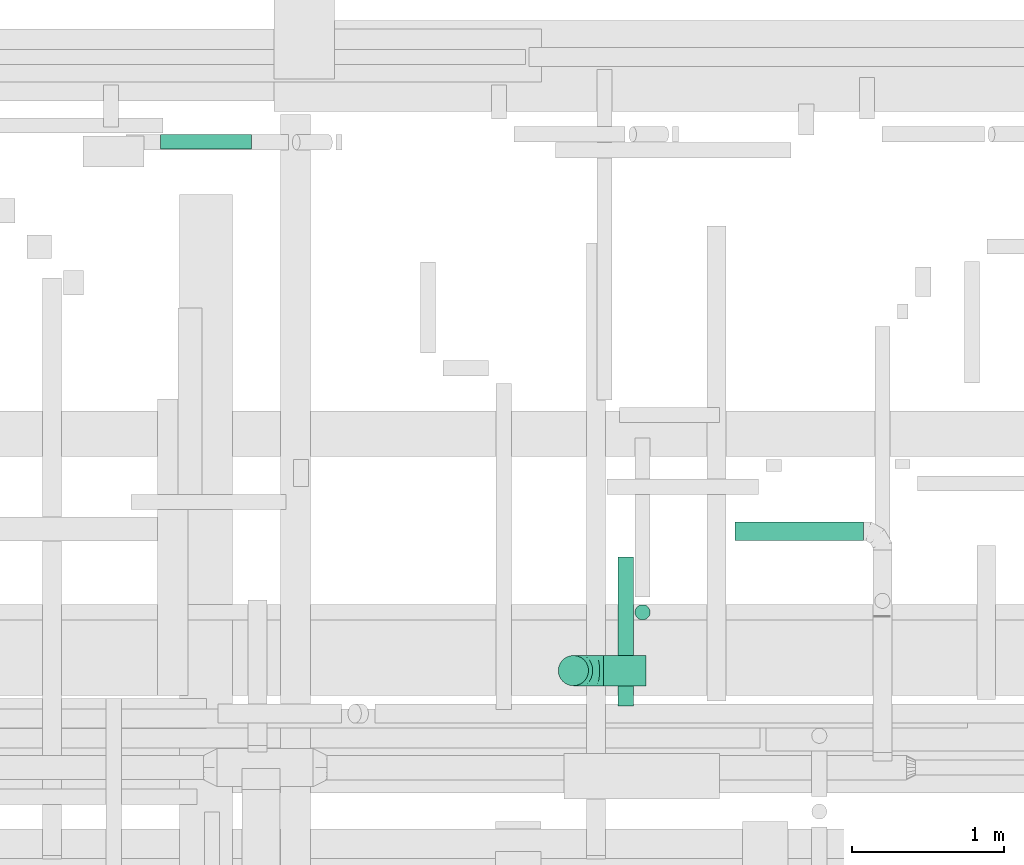
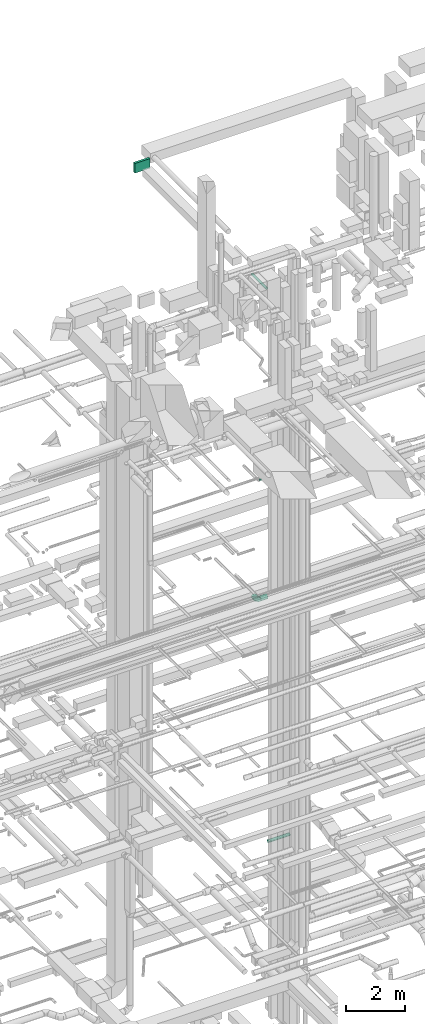
# One storey, part 154 of 337: 5 flow segments, 1 flow fitting.
"""IFC2X3 building model written with IfcOpenShell, lengths in millimetres."""

from ifc_helpers import new_model, entity, si_unit, converted_unit, derived_unit, direction, frame, origin, origin_2d_with_axis, place, context, subcontext, project, spatial, rectangle, circle, extrude, faceted_brep, source, transform, mapped, material, type_object, type_shapes, element, save


model = new_model("IFC2X3")

# Units and contexts
model_context = context("Model", 3, precision=0.01, world=origin(), true_north=direction((6.12303176911189e-17, 1.0)))
body_context = subcontext(model_context, "Body", "Model", "MODEL_VIEW")
ifc_project = project(units=[si_unit("LENGTHUNIT", "METRE", prefix="MILLI"), si_unit("AREAUNIT", "SQUARE_METRE"), si_unit("VOLUMEUNIT", "CUBIC_METRE"), converted_unit("PLANEANGLEUNIT", "DEGREE", entity("IfcRatioMeasure", 0.0174532925199433), si_unit("PLANEANGLEUNIT", "RADIAN"), dimensions=[0, 0, 0, 0, 0, 0, 0]), si_unit("MASSUNIT", "GRAM", prefix="KILO"), derived_unit("MASSDENSITYUNIT", [(si_unit("MASSUNIT", "GRAM", prefix="KILO"), 1), (si_unit("LENGTHUNIT", "METRE"), -3)]), derived_unit("MOMENTOFINERTIAUNIT", [(si_unit("LENGTHUNIT", "METRE"), 4)]), si_unit("TIMEUNIT", "SECOND"), si_unit("FREQUENCYUNIT", "HERTZ"), si_unit("THERMODYNAMICTEMPERATUREUNIT", "DEGREE_CELSIUS"), derived_unit("THERMALTRANSMITTANCEUNIT", [(si_unit("MASSUNIT", "GRAM", prefix="KILO"), 1), (si_unit("THERMODYNAMICTEMPERATUREUNIT", "KELVIN"), -1), (si_unit("TIMEUNIT", "SECOND"), -3)]), derived_unit("VOLUMETRICFLOWRATEUNIT", [(si_unit("LENGTHUNIT", "METRE"), 3), (si_unit("TIMEUNIT", "SECOND"), -1)]), derived_unit("MASSFLOWRATEUNIT", [(si_unit("MASSUNIT", "GRAM", prefix="KILO"), 1), (si_unit("TIMEUNIT", "SECOND"), -1)]), derived_unit("ROTATIONALFREQUENCYUNIT", [(si_unit("TIMEUNIT", "SECOND"), -1)]), si_unit("ELECTRICCURRENTUNIT", "AMPERE"), si_unit("ELECTRICVOLTAGEUNIT", "VOLT"), si_unit("POWERUNIT", "WATT"), si_unit("FORCEUNIT", "NEWTON", prefix="KILO"), si_unit("ILLUMINANCEUNIT", "LUX"), si_unit("LUMINOUSFLUXUNIT", "LUMEN"), si_unit("LUMINOUSINTENSITYUNIT", "CANDELA"), derived_unit("USERDEFINED", [(si_unit("MASSUNIT", "GRAM", prefix="KILO"), -1), (si_unit("LENGTHUNIT", "METRE"), -2), (si_unit("TIMEUNIT", "SECOND"), 3), (si_unit("LUMINOUSFLUXUNIT", "LUMEN"), 1)]), derived_unit("LINEARVELOCITYUNIT", [(si_unit("LENGTHUNIT", "METRE"), 1), (si_unit("TIMEUNIT", "SECOND"), -1)]), si_unit("PRESSUREUNIT", "PASCAL"), derived_unit("USERDEFINED", [(si_unit("LENGTHUNIT", "METRE"), -2), (si_unit("MASSUNIT", "GRAM", prefix="KILO"), 1), (si_unit("TIMEUNIT", "SECOND"), -2)]), derived_unit("LINEARFORCEUNIT", [(si_unit("MASSUNIT", "GRAM", prefix="KILO"), 1), (si_unit("LENGTHUNIT", "METRE"), 1), (si_unit("TIMEUNIT", "SECOND"), -2), (si_unit("LENGTHUNIT", "METRE"), -1)]), derived_unit("PLANARFORCEUNIT", [(si_unit("MASSUNIT", "GRAM", prefix="KILO"), 1), (si_unit("LENGTHUNIT", "METRE"), 1), (si_unit("TIMEUNIT", "SECOND"), -2), (si_unit("LENGTHUNIT", "METRE"), -2)])], contexts=[model_context])

# Site, building, storey
site_placement = place(None, origin())
site = spatial("IfcSite", under=ifc_project, at=site_placement, CompositionType="ELEMENT")
building_placement = place(site_placement, origin())
building = spatial("IfcBuilding", under=site, at=building_placement, CompositionType="ELEMENT")
storey_placement = place(building_placement, origin())
storey = spatial("IfcBuildingStorey", under=building, at=storey_placement, CompositionType="ELEMENT", Elevation=0.0)

# Flow segments
duct_segment_type_1 = type_object("IfcDuctSegmentType", PredefinedType="NOTDEFINED")
flow_segment_1_placement = place(storey_placement, frame((29199.08, 19306.91, 31250.05)))
element("IfcFlowSegment", 1, at=flow_segment_1_placement, inside=storey, type_object=duct_segment_type_1, context=body_context, shape_type="SweptSolid", body=[
    extrude(rectangle(XDim=97.6957532539972, YDim=599.999999999998, at=origin_2d_with_axis()), frame((300.0, 48.85, 0.0), z_axis=(0.0, 0.0, 1.0), x_axis=(0.0, 1.0, 0.0)), (0.0, 0.0, 1.0), 399.999999999996),
])
duct_segment_type_2 = type_object("IfcDuctSegmentType", PredefinedType="NOTDEFINED")
flow_segment_2_placement = place(storey_placement, frame((32123.57, 15763.84, 14475.4)))
element("IfcFlowSegment", 2, at=flow_segment_2_placement, inside=storey, type_object=duct_segment_type_2, context=body_context, shape_type="SweptSolid", body=[
    extrude(circle(Radius=100.0, at=origin_2d_with_axis()), frame((0.0, 101.6, 101.6), z_axis=(1.0, 0.0, 0.0), x_axis=(0.0, -1.0, 0.0)), (0.0, 0.0, 1.0), 280.000000000006),
])
flow_segment_3_placement = place(storey_placement, frame((32990.02, 16720.84, 3535.9)))
element("IfcFlowSegment", 3, at=flow_segment_3_placement, inside=storey, type_object=duct_segment_type_2, context=body_context, shape_type="SweptSolid", body=[
    extrude(circle(Radius=62.5, at=origin_2d_with_axis()), frame((0.0, 64.1, 64.1), z_axis=(1.0, 0.0, 0.0), x_axis=(0.0, 1.0, 0.0)), (0.0, 0.0, 1.0), 847.500000000054),
])
flow_segment_4_placement = place(storey_placement, frame((32328.14, 16198.76, 19200.0)))
element("IfcFlowSegment", 4, at=flow_segment_4_placement, inside=storey, type_object=duct_segment_type_2, context=body_context, shape_type="SweptSolid", body=[
    extrude(circle(Radius=50.0, at=origin_2d_with_axis()), frame((51.6, 51.6, 0.0)), (0.0, 0.0, 1.0), 30.0000000000062),
])
flow_segment_5_placement = place(storey_placement, frame((32217.81, 15632.53, 27548.4)))
element("IfcFlowSegment", 5, at=flow_segment_5_placement, inside=storey, type_object=duct_segment_type_2, context=body_context, shape_type="SweptSolid", body=[
    extrude(circle(Radius=50.0, at=origin_2d_with_axis()), frame((51.6, 0.0, 51.6), z_axis=(0.0, 1.0, 0.0), x_axis=(1.0, 0.0, 0.0)), (0.0, 0.0, 1.0), 981.399999999996),
])

# Flow fitting
ifc_material = material()
duct_fitting_type = type_object("IfcDuctFittingType", PredefinedType="NOTDEFINED", material=ifc_material)
shared_shape = source(origin(), body_context, "Body", "Brep", [
    faceted_brep([(-200.0, 0.0, -100.0), (-200.0, -25.88, -96.59), (-200.0, -50.0, -86.6), (-200.0, -70.71, -70.71), (-200.0, -86.6, -50.0), (-200.0, -96.59, -25.88), (-200.0, -100.0, 0.0), (-200.0, -96.59, 25.88), (-200.0, -86.6, 50.0), (-200.0, -70.71, 70.71), (-200.0, -50.0, 86.6), (-200.0, -25.88, 96.59), (-200.0, 0.0, 100.0), (-200.0, 25.88, 96.59), (-200.0, 50.0, 86.6), (-200.0, 70.71, 70.71), (-200.0, 86.6, 50.0), (-200.0, 96.59, 25.88), (-200.0, 100.0, 0.0), (-200.0, 96.59, -25.88), (-200.0, 86.6, -50.0), (-200.0, 70.71, -70.71), (-200.0, 50.0, -86.6), (-200.0, 25.88, -96.59), (-153.35, 25.88, 96.59), (-159.81, 50.0, 86.6), (-146.41, 0.0, 100.0), (-165.36, 70.71, 70.71), (-172.29, 96.59, 25.88), (-173.21, 100.0, 0.0), (-169.62, 86.6, 50.0), (-169.62, 86.6, -50.0), (-165.36, 70.71, -70.71), (-172.29, 96.59, -25.88), (-153.35, 25.88, -96.59), (-146.41, 0.0, -100.0), (-159.81, 50.0, -86.6), (-139.48, -25.88, -96.59), (-133.01, -50.0, -86.6), (-127.46, -70.71, -70.71), (-123.21, -86.6, -50.0), (-120.53, -96.59, -25.88), (-119.62, -100.0, 0.0), (-120.53, -96.59, 25.88), (-123.21, -86.6, 50.0), (-127.46, -70.71, 70.71), (-133.01, -50.0, 86.6), (-139.48, -25.88, 96.59), (-72.54, 72.54, 96.59), (-90.19, 90.19, 86.6), (-53.59, 53.59, 100.0), (-105.35, 105.35, 70.71), (-116.99, 116.99, 50.0), (-124.3, 124.3, 25.88), (-126.79, 126.79, 0.0), (-124.3, 124.3, -25.88), (-116.99, 116.99, -50.0), (-105.35, 105.35, -70.71), (-72.54, 72.54, -96.59), (-53.59, 53.59, -100.0), (-90.19, 90.19, -86.6), (-34.64, 34.64, -96.59), (-16.99, 16.99, -86.6), (-1.83, 1.83, -70.71), (9.81, -9.81, -50.0), (17.12, -17.12, -25.88), (19.62, -19.62, 0.0), (17.12, -17.12, 25.88), (9.81, -9.81, 50.0), (-1.83, 1.83, 70.71), (-16.99, 16.99, 86.6), (-34.64, 34.64, 96.59), (-25.88, 153.35, 96.59), (-50.0, 159.81, 86.6), (0.0, 146.41, 100.0), (-70.71, 165.36, 70.71), (-86.6, 169.62, 50.0), (-96.59, 172.29, 25.88), (-100.0, 173.21, 0.0), (-96.59, 172.29, -25.88), (-86.6, 169.62, -50.0), (-70.71, 165.36, -70.71), (-25.88, 153.35, -96.59), (0.0, 146.41, -100.0), (-50.0, 159.81, -86.6), (25.88, 139.48, -96.59), (50.0, 133.01, -86.6), (70.71, 127.46, -70.71), (86.6, 123.21, -50.0), (96.59, 120.53, -25.88), (100.0, 119.62, 0.0), (96.59, 120.53, 25.88), (86.6, 123.21, 50.0), (70.71, 127.46, 70.71), (50.0, 133.01, 86.6), (25.88, 139.48, 96.59), (-25.88, 200.0, -96.59), (-50.0, 200.0, -86.6), (-70.71, 200.0, -70.71), (-86.6, 200.0, -50.0), (-96.59, 200.0, -25.88), (-100.0, 200.0, 0.0), (-96.59, 200.0, 25.88), (-86.6, 200.0, 50.0), (-70.71, 200.0, 70.71), (-50.0, 200.0, 86.6), (-25.88, 200.0, 96.59), (0.0, 200.0, 100.0), (25.88, 200.0, 96.59), (50.0, 200.0, 86.6), (70.71, 200.0, 70.71), (86.6, 200.0, 50.0), (96.59, 200.0, 25.88), (100.0, 200.0, 0.0), (96.59, 200.0, -25.88), (86.6, 200.0, -50.0), (70.71, 200.0, -70.71), (50.0, 200.0, -86.6), (25.88, 200.0, -96.59), (0.0, 200.0, -100.0)], [[[0, 1, 2, 3, 4, 5, 6, 7, 8, 9, 10, 11, 12, 13, 14, 15, 16, 17, 18, 19, 20, 21, 22, 23]], [[24, 25, 14, 13]], [[26, 24, 13, 12]], [[14, 25, 27, 15]], [[28, 29, 18, 17]], [[30, 28, 17, 16]], [[15, 27, 30, 16]], [[20, 31, 32, 21]], [[33, 31, 20, 19]], [[18, 29, 33, 19]], [[34, 35, 0, 23]], [[36, 34, 23, 22]], [[32, 36, 22, 21]], [[1, 0, 35, 37]], [[2, 1, 37, 38]], [[38, 39, 3, 2]], [[5, 4, 40, 41]], [[6, 5, 41, 42]], [[39, 40, 4, 3]], [[6, 42, 43, 7]], [[7, 43, 44, 8]], [[8, 44, 45, 9]], [[9, 45, 46, 10]], [[10, 46, 47, 11]], [[26, 12, 11, 47]], [[48, 49, 25, 24]], [[50, 48, 24, 26]], [[27, 25, 49, 51]], [[52, 53, 28, 30]], [[51, 52, 30, 27]], [[29, 28, 53, 54]], [[55, 56, 31, 33]], [[54, 55, 33, 29]], [[32, 31, 56, 57]], [[58, 59, 35, 34]], [[60, 58, 34, 36]], [[57, 60, 36, 32]], [[37, 35, 59, 61]], [[38, 37, 61, 62]], [[39, 38, 62, 63]], [[41, 40, 64, 65]], [[42, 41, 65, 66]], [[63, 64, 40, 39]], [[43, 42, 66, 67]], [[44, 43, 67, 68]], [[68, 69, 45, 44]], [[46, 45, 69, 70]], [[47, 46, 70, 71]], [[26, 47, 71, 50]], [[72, 73, 49, 48]], [[74, 72, 48, 50]], [[51, 49, 73, 75]], [[76, 77, 53, 52]], [[75, 76, 52, 51]], [[54, 53, 77, 78]], [[79, 80, 56, 55]], [[78, 79, 55, 54]], [[57, 56, 80, 81]], [[82, 83, 59, 58]], [[84, 82, 58, 60]], [[81, 84, 60, 57]], [[61, 59, 83, 85]], [[62, 61, 85, 86]], [[63, 62, 86, 87]], [[65, 64, 88, 89]], [[66, 65, 89, 90]], [[87, 88, 64, 63]], [[67, 66, 90, 91]], [[68, 67, 91, 92]], [[92, 93, 69, 68]], [[70, 69, 93, 94]], [[71, 70, 94, 95]], [[50, 71, 95, 74]], [[96, 97, 98, 99, 100, 101, 102, 103, 104, 105, 106, 107, 108, 109, 110, 111, 112, 113, 114, 115, 116, 117, 118, 119]], [[72, 74, 107, 106]], [[73, 72, 106, 105]], [[75, 73, 105, 104]], [[102, 101, 78, 77]], [[103, 102, 77, 76]], [[75, 104, 103, 76]], [[78, 101, 100, 79]], [[79, 100, 99, 80]], [[80, 99, 98, 81]], [[84, 97, 96, 82]], [[82, 96, 119, 83]], [[84, 81, 98, 97]], [[118, 117, 86, 85]], [[119, 118, 85, 83]], [[116, 87, 86, 117]], [[88, 115, 114, 89]], [[89, 114, 113, 90]], [[115, 88, 87, 116]], [[91, 90, 113, 112]], [[92, 91, 112, 111]], [[111, 110, 93, 92]], [[95, 94, 109, 108]], [[74, 95, 108, 107]], [[110, 109, 94, 93]]]),
])
type_shapes(duct_fitting_type, [shared_shape])
flow_fitting_placement = place(storey_placement, frame((31923.57, 15865.44, 14577.0), z_axis=(0.0, 1.0, 0.0), x_axis=(-1.0, 0.0, 0.0)))
element("IfcFlowFitting", 6, at=flow_fitting_placement, inside=storey, type_object=duct_fitting_type, material=ifc_material, context=body_context, shape_type="MappedRepresentation", body=[
    mapped(shared_shape, transform((0.0, 0.0, 0.0), scale=1.0)),
])

save(model, "model.ifc")
